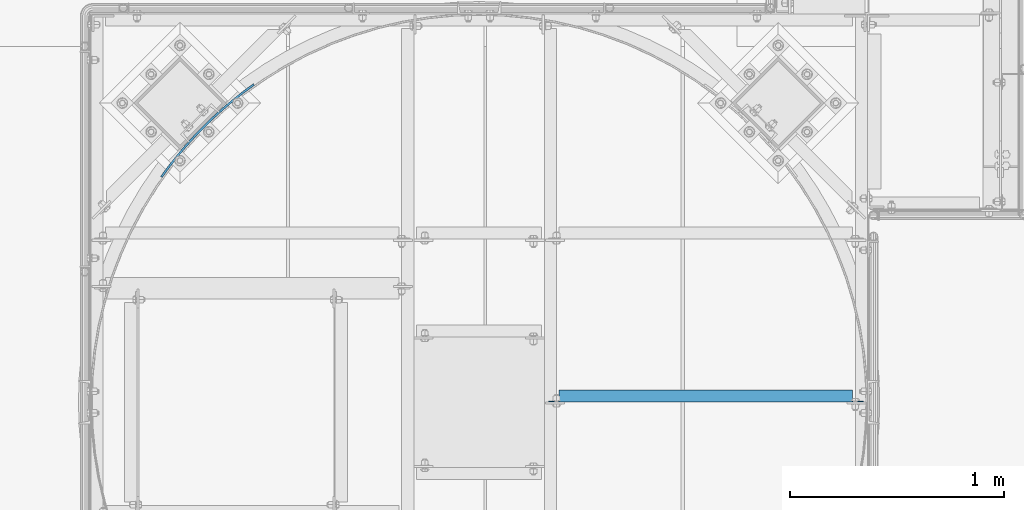
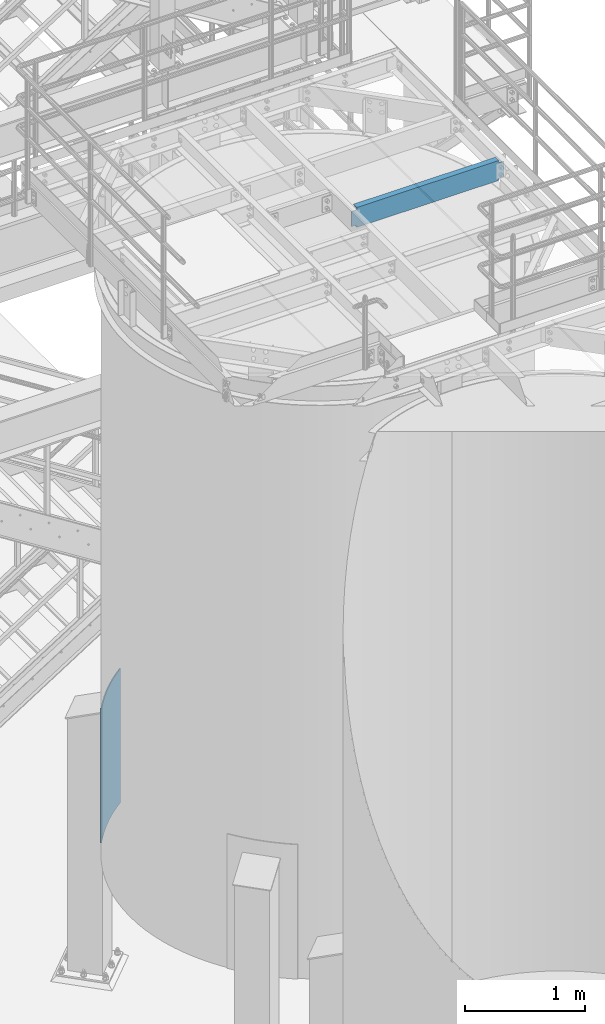
# One storey, part 940 of 1876: 2 beams, 2 elements without a shape of their own.
"""IFC2X3 building model written with IfcOpenShell, lengths in millimetres."""

from ifc_helpers import new_model, si_unit, frame, origin_with_axes, place, context, subcontext, project, spatial, faceted_brep, material, type_object, element, aggregate, save


model = new_model("IFC2X3")

# Units and contexts
model_context = context("Model", 3, precision=1e-05, world=origin_with_axes())
body_context = subcontext(model_context, "Body", "Model", "MODEL_VIEW")
ifc_project = project(units=[si_unit("LENGTHUNIT", "METRE", prefix="MILLI"), si_unit("AREAUNIT", "SQUARE_METRE"), si_unit("VOLUMEUNIT", "CUBIC_METRE"), si_unit("MASSUNIT", "GRAM", prefix="KILO"), si_unit("TIMEUNIT", "SECOND"), si_unit("PLANEANGLEUNIT", "RADIAN"), si_unit("SOLIDANGLEUNIT", "STERADIAN"), si_unit("THERMODYNAMICTEMPERATUREUNIT", "DEGREE_CELSIUS"), si_unit("LUMINOUSINTENSITYUNIT", "LUMEN")], contexts=[model_context])

# Site, building, storey
site_placement = place(None, origin_with_axes())
site = spatial("IfcSite", under=ifc_project, at=site_placement, CompositionType="ELEMENT")
building_placement = place(site_placement, origin_with_axes())
building = spatial("IfcBuilding", under=site, at=building_placement, Name="Undefined", CompositionType="ELEMENT")
storey_placement = place(building_placement, origin_with_axes())
storey = spatial("IfcBuildingStorey", under=building, at=storey_placement, Name="Undefined", CompositionType="ELEMENT", Elevation=0.0)

# Assembly, beam
assembly_1_placement = place(storey_placement, origin_with_axes())
assembly_1 = element("IfcElementAssembly", 1, at=assembly_1_placement, inside=storey, Name="BEAM", AssemblyPlace="NOTDEFINED", PredefinedType="RIGID_FRAME")
ifc_material = material(Name="STEEL/A36")
beam_type_1 = type_object("IfcBeamType", Name="C8X11.5", PredefinedType="NOTDEFINED")
beam_1_placement = place(assembly_1_placement, frame((5486.40333884985, -9509.08937988218, 7896.225), z_axis=(0.0, 0.0, -1.0), x_axis=(1.0, 0.0, 0.0)))
beam_1 = element("IfcBeam", 2, at=beam_1_placement, type_object=beam_type_1, material=ifc_material, Name="BEAM", ObjectType="C8X11.5", context=body_context, shape_type="Brep", body=[
    faceted_brep([(19.0499999999993, 22.2250000000004, -76.2000000000007), (19.0499999999993, 28.5750000000007, -76.2000000000007), (57.1500001907361, 28.5750000000007, -76.2000000000007), (57.1500001907361, 22.2250000000004, -76.2000000000007), (62.0100797087816, 28.5750000000007, -77.1667299225883), (62.0100797087816, 22.2250000000004, -77.1667299225883), (66.1302561769353, 28.5750000000007, -79.9197438230667), (66.1302561769353, 22.2250000000004, -79.9197438230667), (68.8832700774137, 28.5750000000007, -84.0399202912204), (68.8832700774137, 22.2250000000004, -84.0399202912204), (69.8500000000013, 19.0576241940817, -88.8999998092659), (69.8500000000013, 28.5750000000007, -88.8999998092659), (69.8500000000013, 28.5750000000007, -101.6), (69.8500000000013, -28.5750000000007, -101.6), (69.8500000000013, -28.5750000000007, -96.8355949999996), (69.7450369653598, 22.2250000000004, -88.3723149999996), (1441.44713699756, -28.5750000000007, -96.8355949999996), (1441.44713699756, -28.5750000000007, -101.6), (1441.44713699756, 28.5750000000007, -101.6), (1441.44713699756, 28.5750000000007, -88.899999809264), (1441.44713699756, 19.0576241940926, -88.899999809264), (1441.44713699756, -28.5750000000007, 96.8355949999996), (1441.44713699756, -28.5750000000007, 101.6), (69.8500000000013, -28.5750000000007, 101.6), (69.8500000000013, -28.5750000000007, 96.8355949999996), (1441.44713699756, 19.0576241940817, 88.8999998092659), (1441.44713699756, 28.5750000000007, 88.8999998092659), (1441.44713699756, 28.5750000000007, 101.6), (69.8500000000013, 28.5750000000007, 101.6), (57.1500001907361, 22.2250000000004, 76.1999999999989), (57.1500001907361, 28.5750000000007, 76.1999999999989), (19.0499999999993, 28.5750000000007, 76.1999999999989), (19.0499999999993, 22.2250000000004, 76.1999999999989), (62.0100797087816, 22.2250000000004, 77.1667299225865), (62.0100797087816, 28.5750000000007, 77.1667299225865), (66.1302561769353, 22.2250000000004, 79.9197438230649), (66.1302561769353, 28.5750000000007, 79.9197438230649), (68.8832700774137, 22.2250000000004, 84.0399202912186), (68.8832700774137, 28.5750000000007, 84.0399202912186), (69.8500000000013, 19.0576241940926, 88.899999809264), (69.8500000000013, 28.5750000000007, 88.899999809264), (69.7450369653607, 22.2250000000004, 88.3723149999996), (1441.5521000322, 22.2250000000004, 88.3723149999996), (1442.41386692015, 22.2250000000004, 84.0399202912204), (1442.41386692015, 28.5750000000007, 84.0399202912204), (1445.16688082063, 22.2250000000004, 79.9197438230667), (1445.16688082063, 28.5750000000007, 79.9197438230667), (1449.28705728878, 22.2250000000004, 77.1667299225883), (1449.28705728878, 28.5750000000007, 77.1667299225883), (1454.14713680683, 22.2250000000004, 76.2000000000007), (1454.14713680683, 28.5750000000007, 76.2000000000007), (1492.24713699756, 22.2250000000004, 76.2000000000007), (1492.24713699756, 28.5750000000007, 76.2000000000007), (1492.24713699756, 22.2250000000004, -76.1999999999989), (1492.24713699756, 28.5750000000007, -76.1999999999989), (1454.14713680683, 22.2250000000004, -76.1999999999989), (1454.14713680683, 28.5750000000007, -76.1999999999989), (1449.28705728878, 22.2250000000004, -77.1667299225865), (1449.28705728878, 28.5750000000007, -77.1667299225865), (1445.16688082063, 22.2250000000004, -79.9197438230649), (1445.16688082063, 28.5750000000007, -79.9197438230649), (1442.41386692015, 22.2250000000004, -84.0399202912186), (1442.41386692015, 28.5750000000007, -84.0399202912186), (1441.5521000322, 22.2250000000004, -88.3723149999996)], [[[0, 1, 2, 3]], [[3, 2, 4, 5]], [[5, 4, 6, 7]], [[7, 6, 8, 9]], [[10, 11, 12, 13, 14]], [[15, 9, 8, 11, 10]], [[16, 17, 18, 19, 20]], [[21, 22, 23, 24]], [[22, 21, 25, 26, 27]], [[22, 27, 28, 23]], [[29, 30, 31, 32]], [[33, 34, 30, 29]], [[35, 36, 34, 33]], [[37, 38, 36, 35]], [[39, 40, 38, 37, 41]], [[23, 28, 40, 39, 24]], [[41, 42, 25, 21, 24, 39]], [[43, 44, 26, 25, 42]], [[45, 46, 44, 43]], [[47, 48, 46, 45]], [[49, 50, 48, 47]], [[51, 52, 50, 49]], [[52, 51, 53, 54]], [[53, 55, 56, 54]], [[57, 58, 56, 55]], [[59, 60, 58, 57]], [[61, 62, 60, 59]], [[63, 20, 19, 62, 61]], [[14, 16, 20, 63, 15, 10]], [[17, 16, 14, 13]], [[18, 17, 13, 12]], [[6, 4, 2, 1, 31, 30, 34, 36, 38, 40, 28, 27, 26, 44, 46, 48, 50, 52, 54, 56, 58, 60, 62, 19, 18, 12, 11, 8]], [[32, 31, 1, 0]], [[63, 61, 59, 57, 55, 53, 51, 49, 47, 45, 43, 42, 41, 37, 35, 33, 29, 32, 0, 3, 5, 7, 9, 15]]]),
])
aggregate(assembly_1, [beam_1])

assembly_2_placement = place(storey_placement, origin_with_axes())
assembly_2 = element("IfcElementAssembly", 3, at=assembly_2_placement, inside=storey, Name="COLUMN", AssemblyPlace="NOTDEFINED", PredefinedType="RIGID_FRAME")
beam_type_2 = type_object("IfcBeamType", PredefinedType="NOTDEFINED")
beam_2_placement = place(assembly_2_placement, frame((4128.41379378241, -8052.32780208891, 2209.8), z_axis=(0.0, 0.0, 1.0), x_axis=(-0.707106781186547, -0.707106781186548, 0.0)))
beam_2 = element("IfcBeam", 4, at=beam_2_placement, type_object=beam_type_2, material=ifc_material, Name="PLATE", context=body_context, shape_type="Brep", body=[
    faceted_brep([(0.79930179960138, 4.69494652612411, -685.8), (0.79930179960138, 4.69494652612411, 685.8), (61.342263906226, -4.5647055990521, 685.8), (61.342263906226, -4.5647055990521, -685.8), (-0.799301799600926, -4.69494652612411, 685.8), (-0.799301799600926, -4.69494652612411, -685.8), (60.0611937621738, -14.003163327201, -685.8), (60.0611937621738, -14.003163327201, 685.8), (122.16302969072, -11.7776015161726, 685.8), (122.16302969072, -11.7776015161726, -685.8), (121.200950016122, -21.2538891700879, -685.8), (121.200950016122, -21.2538891700879, 685.8), (183.192425169105, -16.9355376990206, 685.8), (183.192425169105, -16.9355376990206, -685.8), (182.550430177147, -26.438877503022, -685.8), (182.550430177147, -26.438877503022, 685.8), (244.361039074185, -20.0326478124662, 685.8), (244.361039074185, -20.0326478124662, -685.8), (244.039858932445, -29.5522312233406, -685.8), (244.039858932445, -29.5522312233406, 685.8), (305.59930179986, -21.0654093844969, 685.8), (305.59930179986, -21.0654093844969, -685.8), (305.599301799861, -30.5904093844983, -685.8), (305.599301799861, -30.5904093844983, 685.8), (366.837564525536, -20.0326478124662, 685.8), (366.837564525536, -20.0326478124662, -685.8), (367.158744667275, -29.5522312233406, -685.8), (367.158744667275, -29.5522312233406, 685.8), (428.006178430616, -16.9355376990206, 685.8), (428.006178430616, -16.9355376990206, -685.8), (428.648173422574, -26.438877503022, -685.8), (428.648173422574, -26.438877503022, 685.8), (489.035573909001, -11.7776015161708, 685.8), (489.035573909001, -11.7776015161708, -685.8), (489.997653583599, -21.253889170086, -685.8), (489.997653583599, -21.253889170086, 685.8), (549.856339693495, -4.5647055990521, 685.8), (549.856339693495, -4.5647055990521, -685.8), (551.137409837547, -14.003163327201, -685.8), (551.137409837547, -14.003163327201, 685.8), (610.39930180012, 4.69494652612411, 685.8), (610.39930180012, 4.69494652612411, -685.8), (611.997905399323, -4.69494652612229, 685.8), (611.997905399323, -4.69494652612229, -685.8)], [[[0, 1, 2, 3]], [[4, 5, 6, 7]], [[5, 4, 1, 0]], [[3, 2, 8, 9]], [[7, 6, 10, 11]], [[9, 8, 12, 13]], [[11, 10, 14, 15]], [[13, 12, 16, 17]], [[15, 14, 18, 19]], [[17, 16, 20, 21]], [[19, 18, 22, 23]], [[21, 20, 24, 25]], [[23, 22, 26, 27]], [[25, 24, 28, 29]], [[27, 26, 30, 31]], [[29, 28, 32, 33]], [[31, 30, 34, 35]], [[33, 32, 36, 37]], [[35, 34, 38, 39]], [[37, 36, 40, 41]], [[36, 32, 28, 24, 20, 16, 12, 8, 2, 1, 4, 7, 11, 15, 19, 23, 27, 31, 35, 39, 42, 40]], [[39, 38, 43, 42]], [[38, 34, 30, 26, 22, 18, 14, 10, 6, 5, 0, 3, 9, 13, 17, 21, 25, 29, 33, 37, 41, 43]], [[42, 43, 41, 40]]]),
])
aggregate(assembly_2, [beam_2])

save(model, "model.ifc")
